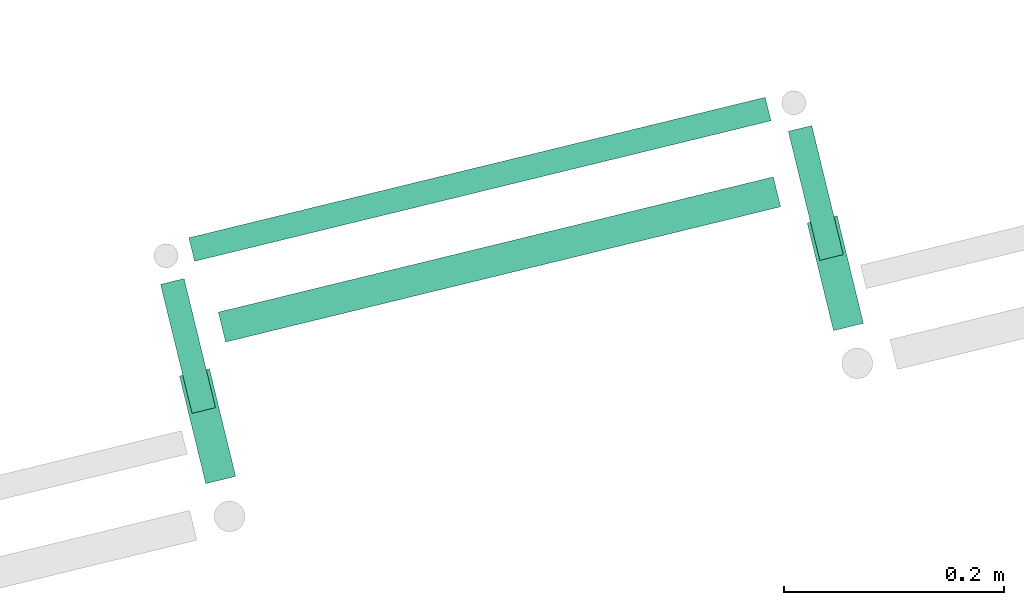
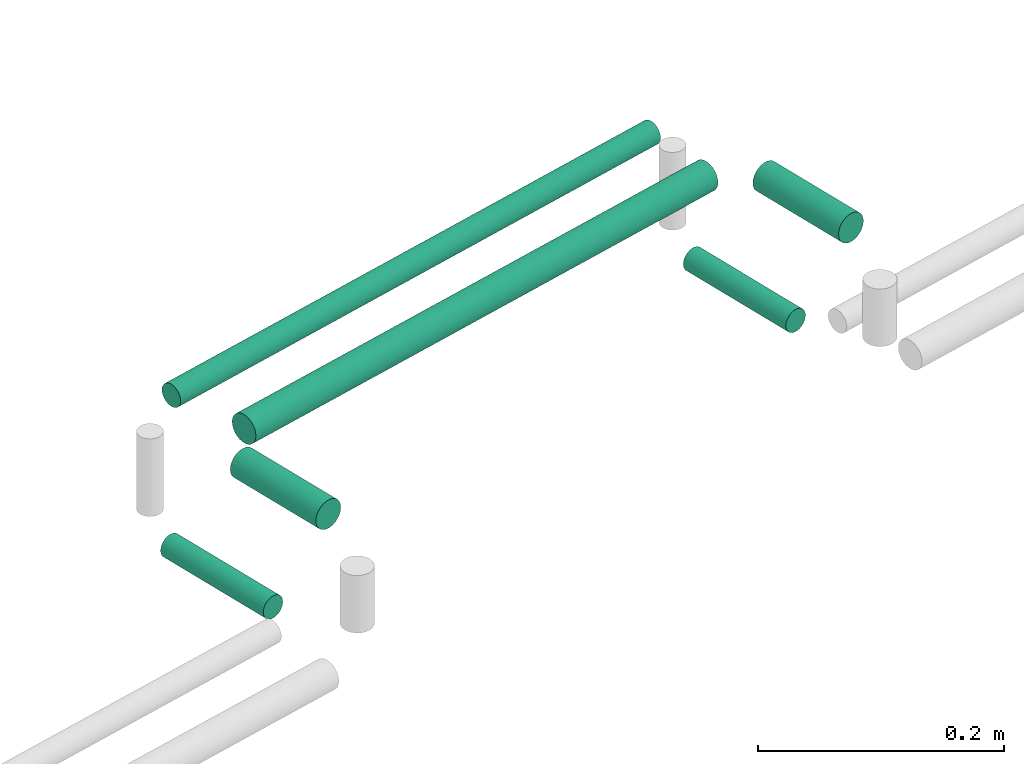
# One storey, part 118 of 331: 6 flow segments.
"""IFC2X3 building model written with IfcOpenShell, lengths in millimetres."""

from ifc_helpers import new_model, entity, si_unit, converted_unit, derived_unit, direction, frame, frame_2d, origin, origin_2d_with_axis, place, context, subcontext, project, spatial, circle, extrude, type_object, element, save


model = new_model("IFC2X3")

# Units and contexts
model_context = context("Model", 3, precision=0.01, world=origin(), true_north=direction((6.12303176911189e-17, 1.0)))
body_context = subcontext(model_context, "Body", "Model", "MODEL_VIEW")
ifc_project = project(units=[si_unit("LENGTHUNIT", "METRE", prefix="MILLI"), si_unit("AREAUNIT", "SQUARE_METRE"), si_unit("VOLUMEUNIT", "CUBIC_METRE"), converted_unit("PLANEANGLEUNIT", "DEGREE", entity("IfcRatioMeasure", 0.0174532925199433), si_unit("PLANEANGLEUNIT", "RADIAN"), dimensions=[0, 0, 0, 0, 0, 0, 0]), si_unit("MASSUNIT", "GRAM", prefix="KILO"), derived_unit("MASSDENSITYUNIT", [(si_unit("MASSUNIT", "GRAM", prefix="KILO"), 1), (si_unit("LENGTHUNIT", "METRE"), -3)]), derived_unit("MOMENTOFINERTIAUNIT", [(si_unit("LENGTHUNIT", "METRE"), 4)]), si_unit("TIMEUNIT", "SECOND"), si_unit("FREQUENCYUNIT", "HERTZ"), si_unit("THERMODYNAMICTEMPERATUREUNIT", "DEGREE_CELSIUS"), derived_unit("THERMALTRANSMITTANCEUNIT", [(si_unit("MASSUNIT", "GRAM", prefix="KILO"), 1), (si_unit("THERMODYNAMICTEMPERATUREUNIT", "KELVIN"), -1), (si_unit("TIMEUNIT", "SECOND"), -3)]), derived_unit("VOLUMETRICFLOWRATEUNIT", [(si_unit("LENGTHUNIT", "METRE"), 3), (si_unit("TIMEUNIT", "SECOND"), -1)]), derived_unit("MASSFLOWRATEUNIT", [(si_unit("MASSUNIT", "GRAM", prefix="KILO"), 1), (si_unit("TIMEUNIT", "SECOND"), -1)]), derived_unit("ROTATIONALFREQUENCYUNIT", [(si_unit("TIMEUNIT", "SECOND"), -1)]), si_unit("ELECTRICCURRENTUNIT", "AMPERE"), si_unit("ELECTRICVOLTAGEUNIT", "VOLT"), si_unit("POWERUNIT", "WATT"), si_unit("FORCEUNIT", "NEWTON", prefix="KILO"), si_unit("ILLUMINANCEUNIT", "LUX"), si_unit("LUMINOUSFLUXUNIT", "LUMEN"), si_unit("LUMINOUSINTENSITYUNIT", "CANDELA"), derived_unit("USERDEFINED", [(si_unit("MASSUNIT", "GRAM", prefix="KILO"), -1), (si_unit("LENGTHUNIT", "METRE"), -2), (si_unit("TIMEUNIT", "SECOND"), 3), (si_unit("LUMINOUSFLUXUNIT", "LUMEN"), 1)]), derived_unit("LINEARVELOCITYUNIT", [(si_unit("LENGTHUNIT", "METRE"), 1), (si_unit("TIMEUNIT", "SECOND"), -1)]), si_unit("PRESSUREUNIT", "PASCAL"), derived_unit("USERDEFINED", [(si_unit("LENGTHUNIT", "METRE"), -2), (si_unit("MASSUNIT", "GRAM", prefix="KILO"), 1), (si_unit("TIMEUNIT", "SECOND"), -2)]), derived_unit("LINEARFORCEUNIT", [(si_unit("MASSUNIT", "GRAM", prefix="KILO"), 1), (si_unit("LENGTHUNIT", "METRE"), 1), (si_unit("TIMEUNIT", "SECOND"), -2), (si_unit("LENGTHUNIT", "METRE"), -1)]), derived_unit("PLANARFORCEUNIT", [(si_unit("MASSUNIT", "GRAM", prefix="KILO"), 1), (si_unit("LENGTHUNIT", "METRE"), 1), (si_unit("TIMEUNIT", "SECOND"), -2), (si_unit("LENGTHUNIT", "METRE"), -2)])], contexts=[model_context])

# Site, building, storey
site_placement = place(None, frame((0.0, -0.00077364408347762, 0.0)))
site = spatial("IfcSite", under=ifc_project, at=site_placement, CompositionType="ELEMENT")
building_placement = place(site_placement, origin())
building = spatial("IfcBuilding", under=site, at=building_placement, CompositionType="ELEMENT")
storey_placement = place(building_placement, origin())
storey = spatial("IfcBuildingStorey", under=building, at=storey_placement, CompositionType="ELEMENT", Elevation=0.0)

# Flow segments
pipe_segment_type = type_object("IfcPipeSegmentType", PredefinedType="NOTDEFINED")
flow_segment_1_placement = place(storey_placement, frame((-17846.782019979, 10778.823957511, 2737.40472776409)))
element("IfcFlowSegment", 1, at=flow_segment_1_placement, inside=storey, type_object=pipe_segment_type, context=body_context, shape_type="SweptSolid", body=[
    extrude(circle(Radius=11.0, at=frame_2d((5.1289078253583e-13, 0.0), x_axis=(1.0, 0.0))), frame((4.20030033920294, 12.2823592375773, 12.5952722359161), z_axis=(0.971553363787441, 0.236820736662373, 0.0), x_axis=(-0.236820736662373, 0.971553363787441, 0.0)), (0.0, 0.0, 1.0), 539.091808251481),
])
flow_segment_2_placement = place(building_placement, frame((-17820.0153933014, 10705.4110025022, 2734.40472776408)))
element("IfcFlowSegment", 2, at=flow_segment_2_placement, inside=storey, type_object=pipe_segment_type, context=body_context, shape_type="SweptSolid", body=[
    extrude(circle(Radius=14.0, at=origin_2d_with_axis()), frame((4.91076254918775, 15.19701932894, 15.595272235916), z_axis=(0.971553363787437, 0.236820736662386, 0.0), x_axis=(-0.236820736662386, 0.971553363787437, 0.0)), (0.0, 0.0, 1.0), 519.091808251468),
])
flow_segment_3_placement = place(building_placement, frame((-17284.8915382447, 10715.8018433386, 2734.40472776408)))
element("IfcFlowSegment", 3, at=flow_segment_3_placement, inside=storey, type_object=pipe_segment_type, context=body_context, shape_type="SweptSolid", body=[
    extrude(circle(Radius=14.0, at=origin_2d_with_axis()), frame((15.19701932894, 102.756973595852, 15.595272235916), z_axis=(0.236820736662368, -0.971553363787442, 0.0), x_axis=(-0.971553363787442, -0.236820736662368, 0.0)), (0.0, 0.0, 1.0), 100.711103160845),
])
flow_segment_4_placement = place(building_placement, frame((-17855.2825594034, 10576.76632882, 2734.4047277641)))
element("IfcFlowSegment", 4, at=flow_segment_4_placement, inside=storey, type_object=pipe_segment_type, context=body_context, shape_type="SweptSolid", body=[
    extrude(circle(Radius=14.0, at=origin_2d_with_axis()), frame((15.19701932894, 102.756973595837, 15.595272235916), z_axis=(0.236820736662646, -0.971553363787374, 0.0), x_axis=(0.971553363787374, 0.236820736662646, 0.0)), (0.0, 0.0, 1.0), 100.711103160836),
])
flow_segment_5_placement = place(building_placement, frame((-17302.1066407696, 10779.6632741948, 2612.40472776408)))
element("IfcFlowSegment", 5, at=flow_segment_5_placement, inside=storey, type_object=pipe_segment_type, context=body_context, shape_type="SweptSolid", body=[
    extrude(circle(Radius=11.0, at=origin_2d_with_axis()), frame((12.2823592375773, 121.477578661612, 12.5952722359161), z_axis=(0.236820736662338, -0.971553363787449, 0.0), x_axis=(-0.971553363787449, -0.236820736662338, 0.0)), (0.0, 0.0, 1.0), 120.711103160844),
])
flow_segment_6_placement = place(building_placement, frame((-17872.4976619284, 10640.6277596762, 2612.40472776408)))
element("IfcFlowSegment", 6, at=flow_segment_6_placement, inside=storey, type_object=pipe_segment_type, context=body_context, shape_type="SweptSolid", body=[
    extrude(circle(Radius=11.0, at=frame_2d((-2.10412640400931e-12, 0.0), x_axis=(1.0, 0.0))), frame((12.2823592375752, 121.47757866161, 12.5952722359161), z_axis=(0.236820736662545, -0.971553363787399, 0.0), x_axis=(-0.971553363787399, -0.236820736662545, 0.0)), (0.0, 0.0, 1.0), 120.711103160849),
])

save(model, "model.ifc")
